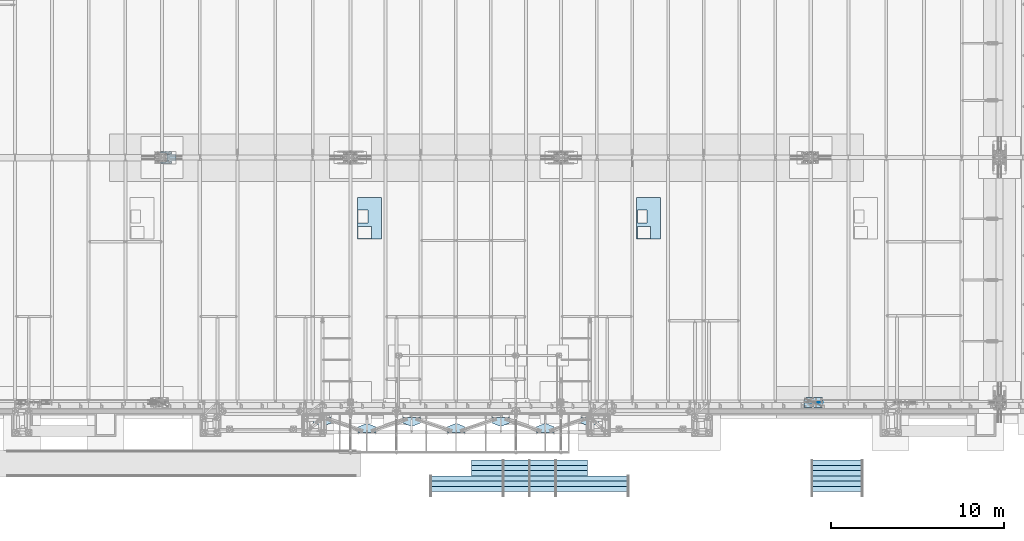
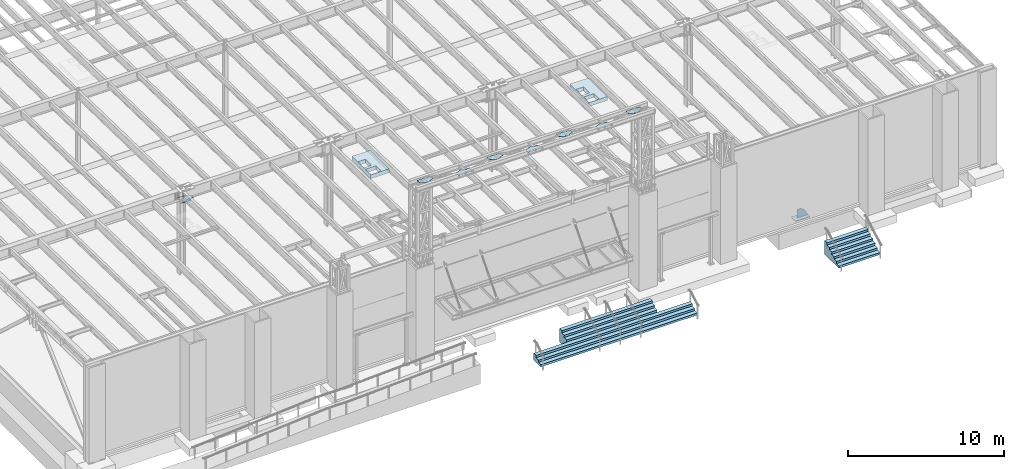
# One storey, part 1409 of 1763: 12 plates, 2 slabs, 8 elements without a shape of their own.
"""IFC2X3 building model written with IfcOpenShell, lengths in millimetres."""

from ifc_helpers import new_model, si_unit, frame, origin_with_axes, place, context, subcontext, project, spatial, faceted_brep, material, type_object, element, aggregate, save


model = new_model("IFC2X3")

# Units and contexts
model_context = context("Model", 3, precision=1e-05, world=origin_with_axes())
body_context = subcontext(model_context, "Body", "Model", "MODEL_VIEW")
ifc_project = project(units=[si_unit("LENGTHUNIT", "METRE", prefix="MILLI"), si_unit("AREAUNIT", "SQUARE_METRE"), si_unit("VOLUMEUNIT", "CUBIC_METRE"), si_unit("MASSUNIT", "GRAM", prefix="KILO"), si_unit("TIMEUNIT", "SECOND"), si_unit("PLANEANGLEUNIT", "RADIAN"), si_unit("SOLIDANGLEUNIT", "STERADIAN"), si_unit("THERMODYNAMICTEMPERATUREUNIT", "DEGREE_CELSIUS"), si_unit("LUMINOUSINTENSITYUNIT", "LUMEN")], contexts=[model_context])

# Site, building, storey
site_placement = place(None, origin_with_axes())
site = spatial("IfcSite", under=ifc_project, at=site_placement, CompositionType="ELEMENT")
building_placement = place(site_placement, origin_with_axes())
building = spatial("IfcBuilding", under=site, at=building_placement, Name="Undefined", CompositionType="ELEMENT")
storey_placement = place(building_placement, origin_with_axes())
storey = spatial("IfcBuildingStorey", under=building, at=storey_placement, Name="Undefined", CompositionType="ELEMENT", Elevation=0.0)

# Assembly, plate
assembly_1_placement = place(storey_placement, origin_with_axes())
assembly_1 = element("IfcElementAssembly", 1, at=assembly_1_placement, inside=storey, Name="B-BOX", AssemblyPlace="NOTDEFINED", PredefinedType="RIGID_FRAME")
ifc_material_1 = material(Name="STEEL/A36")
plate_type_1 = type_object("IfcPlateType", PredefinedType="NOTDEFINED")
plate_1_placement = place(assembly_1_placement, frame((-45030.6148384094, -4264.56192860603, 11747.5), z_axis=(0.0, 1.0, 0.0), x_axis=(1.0, 0.0, 0.0)))
plate_1 = element("IfcPlate", 2, at=plate_1_placement, type_object=plate_type_1, material=ifc_material_1, Name="B-BOX", context=body_context, shape_type="Brep", body=[
    faceted_brep([(596.899999999994, -152.4, 1691.12592269852), (596.899999999994, 152.4, 1691.12592269852), (596.899999999994, 152.4, 939.803901214145), (596.899999999994, -152.4, 939.803901214145), (44.4499877929629, 152.4, 939.803901214145), (44.4499877929629, -152.4, 939.803901214145), (44.4499877929629, 152.4, 1695.45388175919), (44.4499877929629, -152.4, 1695.45388175919), (596.899999999994, 152.4, 1695.45388175919), (596.899999999994, -152.4, 1695.45388175919), (1377.94995117188, -152.4, 0.0), (0.0, -152.4, 0.0), (0.0, 152.4, 0.0), (1377.94995117188, 152.4, 0.0), (1377.94995117188, -152.4, 2422.52490234375), (1377.94995117188, 152.4, 2422.52490234375), (0.0, -152.4, 2422.52490234375), (0.0, 152.4, 2422.52490234375), (44.4499999999971, -152.4, 44.4499999999971), (44.4500244140654, -152.4, 723.903857421872), (800.091015625003, -152.4, 723.903857421872), (800.091015625003, -152.4, 44.4499999999971), (44.4499999999971, 152.4, 44.4499999999971), (44.4500244140654, 152.4, 723.903857421872), (800.091015625003, 152.4, 44.4499999999971), (800.091015625003, 152.4, 723.903857421872)], [[[0, 1, 2, 3]], [[3, 2, 4, 5]], [[5, 4, 6, 7]], [[7, 6, 8, 9]], [[9, 8, 1, 0]], [[10, 11, 12, 13]], [[14, 10, 13, 15]], [[16, 14, 15, 17]], [[11, 16, 17, 12]], [[10, 14, 16, 11], [3, 5, 7, 9, 0], [18, 19, 20, 21]], [[18, 22, 23, 19]], [[21, 24, 22, 18]], [[20, 25, 24, 21]], [[19, 23, 25, 20]], [[15, 13, 12, 17], [4, 2, 1, 8, 6], [22, 24, 25, 23]]]),
])
aggregate(assembly_1, [plate_1])

assembly_2_placement = place(storey_placement, origin_with_axes())
assembly_2 = element("IfcElementAssembly", 3, at=assembly_2_placement, inside=storey, Name="B-BOX", AssemblyPlace="NOTDEFINED", PredefinedType="RIGID_FRAME")
plate_2_placement = place(assembly_2_placement, frame((-61183.7978218078, -4264.56192860603, 11747.5), z_axis=(0.0, 1.0, 0.0), x_axis=(1.0, 0.0, 0.0)))
plate_2 = element("IfcPlate", 4, at=plate_2_placement, type_object=plate_type_1, material=ifc_material_1, Name="B-BOX", context=body_context, shape_type="Brep", body=[
    faceted_brep([(596.899999999994, -152.4, 1691.12592269852), (596.899999999994, 152.4, 1691.12592269852), (596.899999999994, 152.4, 939.803901214145), (596.899999999994, -152.4, 939.803901214145), (44.4499877929629, 152.4, 939.803901214145), (44.4499877929629, -152.4, 939.803901214145), (44.4499877929629, 152.4, 1695.45388175919), (44.4499877929629, -152.4, 1695.45388175919), (596.899999999994, 152.4, 1695.45388175919), (596.899999999994, -152.4, 1695.45388175919), (1377.94995117188, -152.4, 0.0), (0.0, -152.4, 0.0), (0.0, 152.4, 0.0), (1377.94995117188, 152.4, 0.0), (1377.94995117188, -152.4, 2422.52490234375), (1377.94995117188, 152.4, 2422.52490234375), (0.0, -152.4, 2422.52490234375), (0.0, 152.4, 2422.52490234375), (44.4499999999971, -152.4, 44.4499999999971), (44.4500244140654, -152.4, 723.903857421872), (800.091015625003, -152.4, 723.903857421872), (800.091015625003, -152.4, 44.4499999999971), (44.4499999999971, 152.4, 44.4499999999971), (44.4500244140654, 152.4, 723.903857421872), (800.091015625003, 152.4, 44.4499999999971), (800.091015625003, 152.4, 723.903857421872)], [[[0, 1, 2, 3]], [[3, 2, 4, 5]], [[5, 4, 6, 7]], [[7, 6, 8, 9]], [[9, 8, 1, 0]], [[10, 11, 12, 13]], [[14, 10, 13, 15]], [[16, 14, 15, 17]], [[11, 16, 17, 12]], [[10, 14, 16, 11], [3, 5, 7, 9, 0], [18, 19, 20, 21]], [[18, 22, 23, 19]], [[21, 24, 22, 18]], [[20, 25, 24, 21]], [[19, 23, 25, 20]], [[15, 13, 12, 17], [4, 2, 1, 8, 6], [22, 24, 25, 23]]]),
])
aggregate(assembly_2, [plate_2])

# Assembly, slab
assembly_3_placement = place(storey_placement, origin_with_axes())
assembly_3 = element("IfcElementAssembly", 5, at=assembly_3_placement, inside=storey, Name="CONC_STAIR", AssemblyPlace="NOTDEFINED", PredefinedType="REINFORCEMENT_UNIT")
ifc_material_2 = material(Name="CONCRETE/3000")
slab_type_1 = type_object("IfcSlabType", PredefinedType="NOTDEFINED")
slab_1_placement = place(assembly_3_placement, frame((-51231.2372736984, -17357.725, 5334.0), z_axis=(0.0, 0.0, -1.0), x_axis=(0.0, 1.0, 0.0)))
slab_1 = element("IfcSlab", 6, at=slab_1_placement, type_object=slab_type_1, material=ifc_material_2, Name="CONC_STAIR", PredefinedType="FLOOR", context=body_context, shape_type="Brep", body=[
    faceted_brep([(-609.599975585934, 3352.80009765625, 1066.80004882812), (-609.599975585934, 3352.80009765625, 533.400024414062), (-609.599975585934, 5791.2, 533.400024414062), (-609.599975585934, 5791.2, 1066.80004882812), (304.799987792972, 3352.80009765625, 1066.80004882812), (304.799987792969, 3352.80009765625, 0.0), (0.0, 3352.80009765625, 0.0), (19.0499992370605, 3352.80009765625, 177.800003051758), (-304.799987792969, 3352.80009765625, 177.800003051758), (-285.75, 3352.80009765625, 355.600006103516), (-609.599975585938, 3352.80009765625, 355.600006103516), (-590.549987792969, 3352.80009765625, 533.400024414062), (-1524.0, -5791.2, 889.0), (-1504.94995117188, -5791.2, 1066.80004882812), (-1504.94995117188, 5791.2, 1066.80004882812), (-1524.0, 5791.2, 889.0), (-1200.14990234375, -5791.2, 889.0), (-1200.14990234375, 5791.2, 889.0), (-1219.19995117188, -5791.2, 711.200012207031), (-1219.19995117188, 5791.2, 711.200012207031), (-895.350036621094, -5791.2, 711.200012207031), (-895.350036621094, 5791.2, 711.200012207031), (-914.400024414062, -5791.2, 533.400024414062), (-914.400024414062, 5791.2, 533.400024414062), (-609.599975585945, -5791.2, 533.400024414062), (-609.599975585945, -5791.2, 1066.80004882812), (-609.599975585945, -3352.80009765625, 533.400024414062), (-609.599975585945, -3352.80009765625, 1066.80004882812), (304.799987792958, -3352.80009765625, 1066.80004882812), (-590.549987792969, -3352.80009765625, 533.400024414062), (-609.599975585938, -3352.80009765625, 355.600006103516), (-285.75, -3352.80009765625, 355.600006103516), (-304.799987792969, -3352.80009765625, 177.800003051758), (19.0499992370605, -3352.80009765625, 177.800003051758), (0.0, -3352.80009765625, 0.0), (304.799987792969, -3352.80009765625, 0.0)], [[[0, 1, 2, 3]], [[4, 5, 6, 7, 8, 9, 10, 11, 1, 0]], [[12, 13, 14, 15]], [[16, 12, 15, 17]], [[18, 16, 17, 19]], [[20, 18, 19, 21]], [[22, 20, 21, 23]], [[13, 12, 16, 18, 20, 22, 24, 25]], [[25, 24, 26, 27]], [[28, 27, 26, 29, 30, 31, 32, 33, 34, 35]], [[3, 14, 13, 25, 27, 28, 4, 0]], [[23, 21, 19, 17, 15, 14, 3, 2]], [[29, 26, 24, 22, 23, 2, 1, 11]], [[30, 29, 11, 10]], [[31, 30, 10, 9]], [[32, 31, 9, 8]], [[33, 32, 8, 7]], [[34, 33, 7, 6]], [[35, 34, 6, 5]], [[28, 35, 5, 4]]]),
])
aggregate(assembly_3, [slab_1])

assembly_4_placement = place(storey_placement, origin_with_axes())
assembly_4 = element("IfcElementAssembly", 7, at=assembly_4_placement, inside=storey, Name="CONC_STAIR", AssemblyPlace="NOTDEFINED", PredefinedType="REINFORCEMENT_UNIT")
slab_type_2 = type_object("IfcSlabType", PredefinedType="NOTDEFINED")
slab_2_placement = place(assembly_4_placement, frame((-33425.8372736984, -17357.725, 5334.0), z_axis=(0.0, 0.0, -1.0), x_axis=(0.0, 1.0, 0.0)))
slab_2 = element("IfcSlab", 8, at=slab_2_placement, type_object=slab_type_2, material=ifc_material_2, Name="CONC_STAIR", PredefinedType="FLOOR", context=body_context, shape_type="Brep", body=[
    faceted_brep([(0.0, -1524.0, 0.0), (19.0499992370605, -1524.0, 177.800003051758), (19.0499992370605, 1524.0, 177.800003051758), (0.0, 1524.0, 0.0), (-304.799987792969, -1524.0, 177.800003051758), (-304.799987792969, 1524.0, 177.800003051758), (-285.75, -1524.0, 355.600006103516), (-285.75, 1524.0, 355.600006103516), (-609.599975585938, -1524.0, 355.600006103516), (-609.599975585938, 1524.0, 355.600006103516), (-590.549987792969, -1524.0, 533.400024414062), (-590.549987792969, 1524.0, 533.400024414062), (-914.400024414062, -1524.0, 533.400024414062), (-914.400024414062, 1524.0, 533.400024414062), (-895.350036621094, -1524.0, 711.200012207031), (-895.350036621094, 1524.0, 711.200012207031), (-1219.19995117188, -1524.0, 711.200012207031), (-1219.19995117188, 1524.0, 711.200012207031), (-1200.14990234375, -1524.0, 889.0), (-1200.14990234375, 1524.0, 889.0), (-1524.0, -1524.0, 889.0), (-1524.0, 1524.0, 889.0), (-1504.94995117188, -1524.0, 1066.80004882812), (-1504.94995117188, 1524.0, 1066.80004882812), (304.799987792969, -1524.0, 1066.80004882812), (304.799987792969, 1524.0, 1066.80004882812), (304.799987792969, -1524.0, 0.0), (304.799987792969, 1524.0, 0.0)], [[[0, 1, 2, 3]], [[1, 4, 5, 2]], [[4, 6, 7, 5]], [[6, 8, 9, 7]], [[8, 10, 11, 9]], [[10, 12, 13, 11]], [[12, 14, 15, 13]], [[14, 16, 17, 15]], [[16, 18, 19, 17]], [[18, 20, 21, 19]], [[20, 22, 23, 21]], [[22, 24, 25, 23]], [[24, 26, 27, 25]], [[26, 0, 3, 27]], [[5, 7, 9, 11, 13, 15, 17, 19, 21, 23, 25, 27, 3, 2]], [[26, 24, 22, 20, 18, 16, 14, 12, 10, 8, 6, 4, 1, 0]]]),
])
aggregate(assembly_4, [slab_2])

# Assembly, plate
assembly_5_placement = place(storey_placement, origin_with_axes())
assembly_5 = element("IfcElementAssembly", 9, at=assembly_5_placement, inside=storey, Name="BEAM", AssemblyPlace="NOTDEFINED", PredefinedType="RIGID_FRAME")
plate_type_2 = type_object("IfcPlateType", PredefinedType="NOTDEFINED")
plate_3_placement = place(assembly_5_placement, frame((-61139.3757590498, -15125.7925787181, 18616.6125), z_axis=(1.0, 0.0, 0.0), x_axis=(0.0, -1.0, 0.0)))
plate_3 = element("IfcPlate", 10, at=plate_3_placement, type_object=plate_type_2, material=ifc_material_1, Name="PLATE", context=body_context, shape_type="Brep", body=[
    faceted_brep([(0.0, -4.76249999999982, 0.0), (-185.827865600198, -4.76250000000073, 457.200012207519), (-185.827865600198, 4.76250000000073, 457.200012207519), (0.0, 4.76249999999982, 0.0), (-185.827865600115, -4.76250000000073, 558.799987793456), (-185.827865600115, 4.76250000000073, 558.799987793456), (-3.69800545740873e-09, -4.76250000000073, 1015.99999999999), (-3.69800545740873e-09, 4.76250000000073, 1015.99999999999), (322.172149659062, -4.76250000000073, 1015.99999999913), (322.172149659062, 4.76250000000073, 1015.99999999913), (322.172149658203, -4.76250000000073, -6.40284270048141e-10), (322.172149658203, 4.76250000000073, -6.40284270048141e-10)], [[[0, 1, 2, 3]], [[1, 4, 5, 2]], [[4, 6, 7, 5]], [[6, 8, 9, 7]], [[8, 10, 11, 9]], [[10, 0, 3, 11]], [[5, 7, 9, 11, 3, 2]], [[10, 8, 6, 4, 1, 0]]]),
])

# Assembly, plates
assembly_6_placement = place(storey_placement, origin_with_axes())
assembly_6 = element("IfcElementAssembly", 11, at=assembly_6_placement, inside=storey, Name="BEAM", AssemblyPlace="NOTDEFINED", PredefinedType="RIGID_FRAME")
plate_4_placement = place(assembly_6_placement, frame((-48243.5524105272, -14906.5369720394, 18616.6125), z_axis=(1.0, 0.0, 0.0), x_axis=(0.0, 1.0, 0.0)))
plate_4 = element("IfcPlate", 12, at=plate_4_placement, type_object=plate_type_2, material=ifc_material_1, Name="PLATE", context=body_context, shape_type="Brep", body=[
    faceted_brep([(0.0, -4.76249999999982, 0.0), (-185.827865600198, -4.76250000000073, 457.200012207519), (-185.827865600198, 4.76250000000073, 457.200012207519), (0.0, 4.76249999999982, 0.0), (-185.827865600115, -4.76250000000073, 558.799987793456), (-185.827865600115, 4.76250000000073, 558.799987793456), (-3.69800545740873e-09, -4.76250000000073, 1015.99999999999), (-3.69800545740873e-09, 4.76250000000073, 1015.99999999999), (322.172149659062, -4.76250000000073, 1015.99999999913), (322.172149659062, 4.76250000000073, 1015.99999999913), (322.172149658203, -4.76250000000073, -6.40284270048141e-10), (322.172149658203, 4.76250000000073, -6.40284270048141e-10)], [[[0, 1, 2, 3]], [[1, 4, 5, 2]], [[4, 6, 7, 5]], [[6, 8, 9, 7]], [[8, 10, 11, 9]], [[10, 0, 3, 11]], [[5, 7, 9, 11, 3, 2]], [[10, 8, 6, 4, 1, 0]]]),
])
plate_5_placement = place(assembly_6_placement, frame((-63718.5025943605, -14906.5368686383, 18616.6125), z_axis=(1.0, 0.0, 0.0), x_axis=(0.0, 1.0, 0.0)))
plate_5 = element("IfcPlate", 13, at=plate_5_placement, type_object=plate_type_2, material=ifc_material_1, Name="PLATE", context=body_context, shape_type="Brep", body=[
    faceted_brep([(0.0, -4.76249999999982, 0.0), (-185.827865600198, -4.76250000000073, 457.200012207519), (-185.827865600198, 4.76250000000073, 457.200012207519), (0.0, 4.76249999999982, 0.0), (-185.827865600115, -4.76250000000073, 558.799987793456), (-185.827865600115, 4.76250000000073, 558.799987793456), (-3.69800545740873e-09, -4.76250000000073, 1015.99999999999), (-3.69800545740873e-09, 4.76250000000073, 1015.99999999999), (322.172149659062, -4.76250000000073, 1015.99999999913), (322.172149659062, 4.76250000000073, 1015.99999999913), (322.172149658203, -4.76250000000073, -6.40284270048141e-10), (322.172149658203, 4.76250000000073, -6.40284270048141e-10)], [[[0, 1, 2, 3]], [[1, 4, 5, 2]], [[4, 6, 7, 5]], [[6, 8, 9, 7]], [[8, 10, 11, 9]], [[10, 0, 3, 11]], [[5, 7, 9, 11, 3, 2]], [[10, 8, 6, 4, 1, 0]]]),
])
plate_6_placement = place(assembly_6_placement, frame((-58560.185874869, -14906.5369047972, 18616.6125), z_axis=(1.0, 0.0, 0.0), x_axis=(0.0, 1.0, 0.0)))
plate_6 = element("IfcPlate", 14, at=plate_6_placement, type_object=plate_type_2, material=ifc_material_1, Name="PLATE", context=body_context, shape_type="Brep", body=[
    faceted_brep([(0.0, -4.76249999999982, 0.0), (-185.827865600198, -4.76250000000073, 457.200012207519), (-185.827865600198, 4.76250000000073, 457.200012207519), (0.0, 4.76249999999982, 0.0), (-185.827865600115, -4.76250000000073, 558.799987793456), (-185.827865600115, 4.76250000000073, 558.799987793456), (-3.69800545740873e-09, -4.76250000000073, 1015.99999999999), (-3.69800545740873e-09, 4.76250000000073, 1015.99999999999), (322.172149659062, -4.76250000000073, 1015.99999999913), (322.172149659062, 4.76250000000073, 1015.99999999913), (322.172149658203, -4.76250000000073, -6.40284270048141e-10), (322.172149658203, 4.76250000000073, -6.40284270048141e-10)], [[[0, 1, 2, 3]], [[1, 4, 5, 2]], [[4, 6, 7, 5]], [[6, 8, 9, 7]], [[8, 10, 11, 9]], [[10, 0, 3, 11]], [[5, 7, 9, 11, 3, 2]], [[10, 8, 6, 4, 1, 0]]]),
])
plate_7_placement = place(assembly_6_placement, frame((-53401.8691428777, -14906.5369361376, 18616.6125), z_axis=(1.0, 0.0, 0.0), x_axis=(0.0, 1.0, 0.0)))
plate_7 = element("IfcPlate", 15, at=plate_7_placement, type_object=plate_type_2, material=ifc_material_1, Name="PLATE", context=body_context, shape_type="Brep", body=[
    faceted_brep([(0.0, -4.76249999999982, 0.0), (-185.827865600198, -4.76250000000073, 457.200012207519), (-185.827865600198, 4.76250000000073, 457.200012207519), (0.0, 4.76249999999982, 0.0), (-185.827865600115, -4.76250000000073, 558.799987793456), (-185.827865600115, 4.76250000000073, 558.799987793456), (-3.69800545740873e-09, -4.76250000000073, 1015.99999999999), (-3.69800545740873e-09, 4.76250000000073, 1015.99999999999), (322.172149659062, -4.76250000000073, 1015.99999999913), (322.172149659062, 4.76250000000073, 1015.99999999913), (322.172149658203, -4.76250000000073, -6.40284270048141e-10), (322.172149658203, 4.76250000000073, -6.40284270048141e-10)], [[[0, 1, 2, 3]], [[1, 4, 5, 2]], [[4, 6, 7, 5]], [[6, 8, 9, 7]], [[8, 10, 11, 9]], [[10, 0, 3, 11]], [[5, 7, 9, 11, 3, 2]], [[10, 8, 6, 4, 1, 0]]]),
])
aggregate(assembly_6, [plate_4, plate_5, plate_6, plate_7])

# Plate
plate_8_placement = place(assembly_5_placement, frame((-55981.0274546335, -15125.7917648804, 18616.6125), z_axis=(1.0, 0.0, 0.0), x_axis=(0.0, -1.0, 0.0)))
plate_8 = element("IfcPlate", 16, at=plate_8_placement, type_object=plate_type_2, material=ifc_material_1, Name="PLATE", context=body_context, shape_type="Brep", body=[
    faceted_brep([(0.0, -4.76249999999982, 0.0), (-185.827865600198, -4.76250000000073, 457.200012207519), (-185.827865600198, 4.76250000000073, 457.200012207519), (0.0, 4.76249999999982, 0.0), (-185.827865600115, -4.76250000000073, 558.799987793456), (-185.827865600115, 4.76250000000073, 558.799987793456), (-3.69800545740873e-09, -4.76250000000073, 1015.99999999999), (-3.69800545740873e-09, 4.76250000000073, 1015.99999999999), (322.172149659062, -4.76250000000073, 1015.99999999913), (322.172149659062, 4.76250000000073, 1015.99999999913), (322.172149658203, -4.76250000000073, -6.40284270048141e-10), (322.172149658203, 4.76250000000073, -6.40284270048141e-10)], [[[0, 1, 2, 3]], [[1, 4, 5, 2]], [[4, 6, 7, 5]], [[6, 8, 9, 7]], [[8, 10, 11, 9]], [[10, 0, 3, 11]], [[5, 7, 9, 11, 3, 2]], [[10, 8, 6, 4, 1, 0]]]),
])

plate_9_placement = place(assembly_5_placement, frame((-50822.7107759672, -15125.7923459678, 18616.6125), z_axis=(1.0, 0.0, 0.0), x_axis=(0.0, -1.0, 0.0)))
plate_9 = element("IfcPlate", 17, at=plate_9_placement, type_object=plate_type_2, material=ifc_material_1, Name="PLATE", context=body_context, shape_type="Brep", body=[
    faceted_brep([(0.0, -4.76249999999982, 0.0), (-185.827865600198, -4.76250000000073, 457.200012207519), (-185.827865600198, 4.76250000000073, 457.200012207519), (0.0, 4.76249999999982, 0.0), (-185.827865600115, -4.76250000000073, 558.799987793456), (-185.827865600115, 4.76250000000073, 558.799987793456), (-3.69800545740873e-09, -4.76250000000073, 1015.99999999999), (-3.69800545740873e-09, 4.76250000000073, 1015.99999999999), (322.172149659062, -4.76250000000073, 1015.99999999913), (322.172149659062, 4.76250000000073, 1015.99999999913), (322.172149658203, -4.76250000000073, -6.40284270048141e-10), (322.172149658203, 4.76250000000073, -6.40284270048141e-10)], [[[0, 1, 2, 3]], [[1, 4, 5, 2]], [[4, 6, 7, 5]], [[6, 8, 9, 7]], [[8, 10, 11, 9]], [[10, 0, 3, 11]], [[5, 7, 9, 11, 3, 2]], [[10, 8, 6, 4, 1, 0]]]),
])

aggregate(assembly_5, [plate_3, plate_8, plate_9])

# Assembly, plate
assembly_7_placement = place(storey_placement, origin_with_axes())
assembly_7 = element("IfcElementAssembly", 18, at=assembly_7_placement, inside=storey, Name="PLATE", AssemblyPlace="NOTDEFINED", PredefinedType="RIGID_FRAME")
ifc_material_3 = material(Name="STEEL/A572-50")
plate_type_3 = type_object("IfcPlateType", PredefinedType="NOTDEFINED")
plate_10_placement = place(assembly_7_placement, frame((-71697.262287273, 104.775022526296, 11052.7336774667), z_axis=(-1.0, 0.0, 0.0), x_axis=(0.0, 1.0, 0.0)))
plate_10 = element("IfcPlate", 19, at=plate_10_placement, type_object=plate_type_3, material=ifc_material_3, Name="PLATE", context=body_context, shape_type="Brep", body=[
    faceted_brep([(603.250004029821, -14.2875000001914, 358.837852889541), (603.250004026169, 14.2874999998094, 358.996583119966), (601.385257579059, 14.2874999998148, 347.222854223699), (601.385257582711, -14.2875000001841, 347.064123993274), (595.973552077036, 14.2874999998221, 336.601619897599), (595.973552080687, -14.2875000001786, 336.442889667174), (587.544622978227, 14.2874999998257, 328.172560595354), (587.544622981879, -14.287500000175, 328.013830364929), (576.923552618695, 14.2874999998276, 322.760771398258), (576.923552622347, -14.2875000001713, 322.602041167833), (565.150005402216, 14.2874999998312, 320.895995957093), (565.150005405868, -14.2875000001713, 320.737265726653), (553.376458590587, 14.2874999998276, 322.760771364032), (553.376458594238, -14.2875000001713, 322.602041133607), (542.755388547501, 14.2874999998257, 328.172560288964), (542.755388551152, -14.287500000175, 328.013830058539), (534.326459574763, 14.2874999998221, 336.601619143767), (534.326459578414, -14.2875000001786, 336.442888913341), (528.914753939965, 14.2874999998148, 347.222852947089), (528.914753943616, -14.2875000001841, 347.064122716663), (527.050007078195, 14.2874999998112, 358.996581367144), (527.050007081847, -14.2875000001914, 358.837851136705), (527.050005838016, 14.2874999997821, 412.933144502182), (527.050005841667, -14.2875000002186, 412.774414271757), (528.914752221755, 14.2874999997748, 424.706873203148), (528.914752225407, -14.2875000002259, 424.548142972722), (534.326457545916, 14.2874999997694, 435.328107392255), (534.326457549568, -14.2875000002314, 435.16937716183), (542.755386387807, 14.2874999997639, 443.757166664596), (542.755386391458, -14.287500000235, 443.598436434171), (553.376456464589, 14.2874999997621, 449.168955969901), (553.376456576447, -14.287499999602, 449.010258667964), (565.150003435811, 14.2874999997621, 451.033731664793), (565.15000354773, -14.2874999996002, 450.875005593225), (576.923550492216, 14.2874999997621, 449.16895651161), (576.923550604909, -14.287499999602, 449.010259209535), (587.54462081798, 14.2874999997639, 443.757167694974), (587.544620821631, -14.287500000235, 443.598437464549), (595.973550047621, 14.2874999997694, 435.328108810412), (595.973550051272, -14.2875000002314, 435.169378579987), (601.385255860337, 14.2874999997748, 424.706874870244), (601.385255863989, -14.2875000002259, 424.548144639804), (603.25000278561, 14.2874999997821, 412.933146255018), (603.250002789261, -14.2875000002186, 412.774416024578), (704.849975585938, 14.2874999995329, 882.67993164064), (704.849975585938, -14.287500000466, 882.67993164061), (704.849975585938, -14.287499999773, 257.200012490852), (704.849975585938, 14.2875000002277, 257.200012376532), (603.24992954226, 14.2874999995329, 882.67993164064), (603.24992954226, -14.2875000004678, 882.679963379604), (603.249929324074, 14.2875000004897, 552.474999679012), (603.249929324074, -14.2874999995092, 552.474999650338), (601.385182657828, 14.2875000004788, 540.701452666704), (601.385182657828, -14.2874999995202, 540.701452638037), (595.973477078782, 14.2875000004697, 530.080382470805), (595.973477078782, -14.2874999995292, 530.080382442138), (587.544548034584, 14.2875000004624, 521.651453443439), (587.544548034584, -14.2874999995365, 521.651453414772), (576.923477827881, 14.2875000004587, 516.239747885607), (576.923477827881, -14.287499999542, 516.239747856933), (565.149930811853, 14.2875000004551, 514.375001242865), (565.149930811853, -14.2874999995438, 514.375001214197), (139.699995941971, 14.2875000004551, 514.375001666958), (139.699995941971, -14.2874999995438, 514.375001638291), (127.926448731243, 14.2875000004587, 516.239748397638), (127.926448731243, -14.287499999542, 516.239748368971), (117.305378396205, 14.2875000004624, 521.651454157451), (117.305378396205, -14.2874999995365, 521.651454128783), (108.876449338545, 14.2875000004697, 530.08038346273), (108.876449338545, -14.2874999995292, 530.080383434062), (103.464743890755, 14.2875000004788, 540.701453956754), (103.464743890755, -14.2874999995202, 540.701453928086), (101.599997505949, 14.2875000004897, 552.475001222258), (101.599997505949, -14.2874999995092, 552.47500119359), (101.600003577159, -14.287500000466, 882.67993164061), (101.600003577159, 14.2874999995329, 882.67993164064), (-5.6429926189594e-06, 14.2874999995329, 882.67993164064), (-5.6429926189594e-06, -14.287500000466, 882.67993164061), (-1.53680616676866e-06, 14.2875000002277, 257.200012208959), (-1.53680616676866e-06, -14.287499999773, 257.200012323279), (139.700007372195, 14.2875000002277, 257.2000123486), (139.700007372195, -14.287499999773, 257.20001246297), (151.473554388223, 14.2875000002277, 255.335265705864), (151.473554388223, -14.287499999773, 255.335265820235), (162.094624594926, 14.2875000002223, 249.923560148025), (162.094624594926, -14.2874999997784, 249.923560262396), (170.523553639124, 14.287500000215, 241.494631120659), (170.523553639124, -14.2874999997857, 241.494631235029), (175.93525921817, 14.2875000002059, 230.87356092476), (175.93525921817, -14.2874999997948, 230.873561039138), (177.800005884416, 14.287500000195, 219.100013912459), (177.800005884416, -14.2874999998057, 219.10001402683), (177.800006103517, 14.2875000000004, -7.27595761418343e-12), (177.800006103517, -14.2875000000004, 1.45519152283669e-11), (527.049945068359, 14.2875000000004, -1.45519152283669e-11), (527.049945068359, -14.2875000000004, 7.27595761418343e-12), (527.049944849361, 14.287500000195, 219.100013725154), (527.049944849361, -14.2874999998057, 219.100013839525), (528.914691492065, 14.2875000002059, 230.873560741165), (528.914691492065, -14.2874999997948, 230.873560855543), (534.32639704987, 14.287500000215, 241.494630947847), (534.32639704987, -14.2874999997857, 241.494631062225), (542.75532607721, 14.2875000002223, 249.923559992014), (542.75532607721, -14.2874999997784, 249.923560106392), (553.376396273088, 14.2875000002277, 255.335265571026), (553.376396273088, -14.287499999773, 255.335265685397), (565.149943285383, 14.2875000002277, 257.200012237234), (565.149943285383, -14.287499999773, 257.200012351605), (175.935259087028, -14.2875000001841, 347.064123993259), (170.523553585002, -14.2875000001786, 336.442889667145), (162.09462448619, -14.287500000175, 328.0138303649), (151.473554126654, -14.2875000001713, 322.602041167804), (139.700006910166, -14.2875000001713, 320.737265726639), (127.926460098541, -14.2875000001713, 322.602041133592), (117.30539005546, -14.287500000175, 328.013830058524), (108.876461082725, -14.2875000001786, 336.442888913327), (103.464755447929, -14.2875000001841, 347.064122716649), (101.600008586159, -14.2875000001914, 358.83785113669), (101.600007345971, -14.2875000002186, 412.774414271742), (103.464753729708, -14.2875000002259, 424.548142972708), (108.876459053869, -14.2875000002314, 435.169377161816), (117.305387895759, -14.287500000235, 443.598436434171), (127.926458080751, -14.287499999602, 449.010258667964), (139.700005052036, -14.2874999996002, 450.875005593225), (151.473552109224, -14.287499999602, 449.010259209535), (162.094622325947, -14.287500000235, 443.598437464549), (170.523551555588, -14.2875000002314, 435.169378579987), (175.935257368305, -14.2875000002259, 424.548144639804), (177.800004293577, -14.2875000002186, 412.774416024578), (177.800005534138, -14.2875000001914, 358.837852889526), (170.523551551937, 14.2874999997694, 435.328108810412), (175.935257364654, 14.2874999997748, 424.706874870244), (162.094622322296, 14.2874999997639, 443.757167694974), (151.473551996532, 14.2874999997621, 449.16895651161), (139.700004940114, 14.2874999997621, 451.033731664793), (127.926457968891, 14.2874999997621, 449.168955969901), (117.305387892108, 14.2874999997639, 443.757166664596), (108.876459050218, 14.2874999997694, 435.328107392255), (103.464753726058, 14.2874999997748, 424.706873203148), (101.60000734232, 14.2874999997821, 412.933144502182), (101.600008582508, 14.2874999998112, 358.996581367115), (103.464755444279, 14.2874999998148, 347.222852947074), (108.876461079075, 14.2874999998221, 336.601619143752), (117.305390051809, 14.2874999998257, 328.172560288949), (127.926460094891, 14.2874999998276, 322.760771364032), (139.700006906516, 14.2874999998312, 320.895995957078), (151.473554123004, 14.2874999998276, 322.760771398243), (162.094624482539, 14.2874999998257, 328.17256059534), (170.523553581351, 14.2874999998221, 336.601619897585), (175.935259083377, 14.2874999998148, 347.222854223684), (177.800005530488, 14.2874999998094, 358.996583119952), (177.800004289927, 14.2874999997821, 412.933146255018)], [[[0, 1, 2, 3]], [[3, 2, 4, 5]], [[5, 4, 6, 7]], [[7, 6, 8, 9]], [[9, 8, 10, 11]], [[11, 10, 12, 13]], [[13, 12, 14, 15]], [[15, 14, 16, 17]], [[17, 16, 18, 19]], [[19, 18, 20, 21]], [[21, 20, 22, 23]], [[23, 22, 24, 25]], [[25, 24, 26, 27]], [[27, 26, 28, 29]], [[29, 28, 30, 31]], [[31, 30, 32, 33]], [[33, 32, 34, 35]], [[35, 34, 36, 37]], [[37, 36, 38, 39]], [[39, 38, 40, 41]], [[41, 40, 42, 43]], [[43, 42, 1, 0]], [[44, 45, 46, 47]], [[45, 44, 48, 49]], [[49, 48, 50, 51]], [[51, 50, 52, 53]], [[53, 52, 54, 55]], [[55, 54, 56, 57]], [[57, 56, 58, 59]], [[59, 58, 60, 61]], [[61, 60, 62, 63]], [[63, 62, 64, 65]], [[65, 64, 66, 67]], [[67, 66, 68, 69]], [[69, 68, 70, 71]], [[71, 70, 72, 73]], [[74, 73, 72, 75]], [[76, 77, 74, 75]], [[77, 76, 78, 79]], [[79, 78, 80, 81]], [[81, 80, 82, 83]], [[83, 82, 84, 85]], [[85, 84, 86, 87]], [[87, 86, 88, 89]], [[89, 88, 90, 91]], [[91, 90, 92, 93]], [[93, 92, 94, 95]], [[95, 94, 96, 97]], [[97, 96, 98, 99]], [[99, 98, 100, 101]], [[101, 100, 102, 103]], [[103, 102, 104, 105]], [[105, 104, 106, 107]], [[46, 107, 106, 47]], [[45, 49, 51, 53, 55, 57, 59, 61, 63, 65, 67, 69, 71, 73, 74, 77, 79, 81, 83, 85, 87, 89, 91, 93, 95, 97, 99, 101, 103, 105, 107, 46], [3, 5, 7, 9, 11, 13, 15, 17, 19, 21, 23, 25, 27, 29, 31, 33, 35, 37, 39, 41, 43, 0], [108, 109, 110, 111, 112, 113, 114, 115, 116, 117, 118, 119, 120, 121, 122, 123, 124, 125, 126, 127, 128, 129]], [[126, 130, 131, 127]], [[125, 132, 130, 126]], [[124, 133, 132, 125]], [[123, 134, 133, 124]], [[122, 135, 134, 123]], [[121, 136, 135, 122]], [[120, 137, 136, 121]], [[119, 138, 137, 120]], [[118, 139, 138, 119]], [[117, 140, 139, 118]], [[116, 141, 140, 117]], [[115, 142, 141, 116]], [[114, 143, 142, 115]], [[113, 144, 143, 114]], [[112, 145, 144, 113]], [[111, 146, 145, 112]], [[110, 147, 146, 111]], [[109, 148, 147, 110]], [[108, 149, 148, 109]], [[129, 150, 149, 108]], [[128, 151, 150, 129]], [[127, 131, 151, 128]], [[104, 102, 100, 98, 96, 94, 92, 90, 88, 86, 84, 82, 80, 78, 76, 75, 72, 70, 68, 66, 64, 62, 60, 58, 56, 54, 52, 50, 48, 44, 47, 106], [38, 36, 34, 32, 30, 28, 26, 24, 22, 20, 18, 16, 14, 12, 10, 8, 6, 4, 2, 1, 42, 40], [130, 132, 133, 134, 135, 136, 137, 138, 139, 140, 141, 142, 143, 144, 145, 146, 147, 148, 149, 150, 151, 131]]]),
])
aggregate(assembly_7, [plate_10])

# Assembly, plates
assembly_8_placement = place(storey_placement, origin_with_axes())
assembly_8 = element("IfcElementAssembly", 20, at=assembly_8_placement, inside=storey, Name="COLUMN", AssemblyPlace="NOTDEFINED", PredefinedType="RIGID_FRAME")
ifc_material_4 = material(Name="STEEL/A572-GR.50")
plate_type_4 = type_object("IfcPlateType", PredefinedType="NOTDEFINED")
plate_11_placement = place(assembly_8_placement, frame((-35076.8372736984, -13716.0, 5130.79999999958), z_axis=(1.0, 0.0, 0.0), x_axis=(0.0, 0.0, 1.0)))
plate_11 = element("IfcPlate", 21, at=plate_11_placement, type_object=plate_type_4, material=ifc_material_4, Name="PLATE", context=body_context, shape_type="Brep", body=[
    faceted_brep([(0.0, -12.6999999999971, -1.81898940354586e-12), (0.0, -12.7000000000007, 812.799987792969), (0.0, 12.7000000000007, 812.799987792969), (0.0, 12.6999999999971, -1.81898940354586e-12), (399.113464355469, -12.7000000000007, 613.618408203125), (399.113464355469, 12.7000000000007, 613.618408203125), (661.864318847656, -12.7000000000007, 289.151641845703), (661.864318847656, 12.7000000000007, 289.151641845703), (661.864318847656, -12.7000000000007, 0.0), (661.864318847656, 12.7000000000007, 0.0)], [[[0, 1, 2, 3]], [[1, 4, 5, 2]], [[4, 6, 7, 5]], [[6, 8, 9, 7]], [[8, 0, 3, 9]], [[5, 7, 9, 3, 2]], [[8, 6, 4, 1, 0]]]),
])
plate_type_5 = type_object("IfcPlateType", PredefinedType="NOTDEFINED")
plate_12_placement = place(assembly_8_placement, frame((-35330.8372736984, -13436.6, 5105.4), z_axis=(1.0, 0.0, 0.0), x_axis=(0.0, -1.0, 0.0)))
plate_12 = element("IfcPlate", 22, at=plate_12_placement, type_object=plate_type_5, material=ifc_material_4, Name="PLATE", context=body_context, shape_type="Brep", body=[
    faceted_brep([(0.0, -25.4000000000015, 0.0), (0.0, -25.3999999999996, 1066.80004882812), (0.0, 25.3999999999996, 1066.80004882812), (0.0, 25.4000000000015, 0.0), (558.799987792969, -25.3999999999996, 1066.80004882812), (558.799987792969, 25.3999999999996, 1066.80004882812), (558.799987792969, -25.3999999999996, 0.0), (558.799987792969, 25.3999999999996, 0.0)], [[[0, 1, 2, 3]], [[1, 4, 5, 2]], [[4, 6, 7, 5]], [[6, 0, 3, 7]], [[5, 7, 3, 2]], [[6, 4, 1, 0]]]),
])
aggregate(assembly_8, [plate_11, plate_12])

save(model, "model.ifc")
